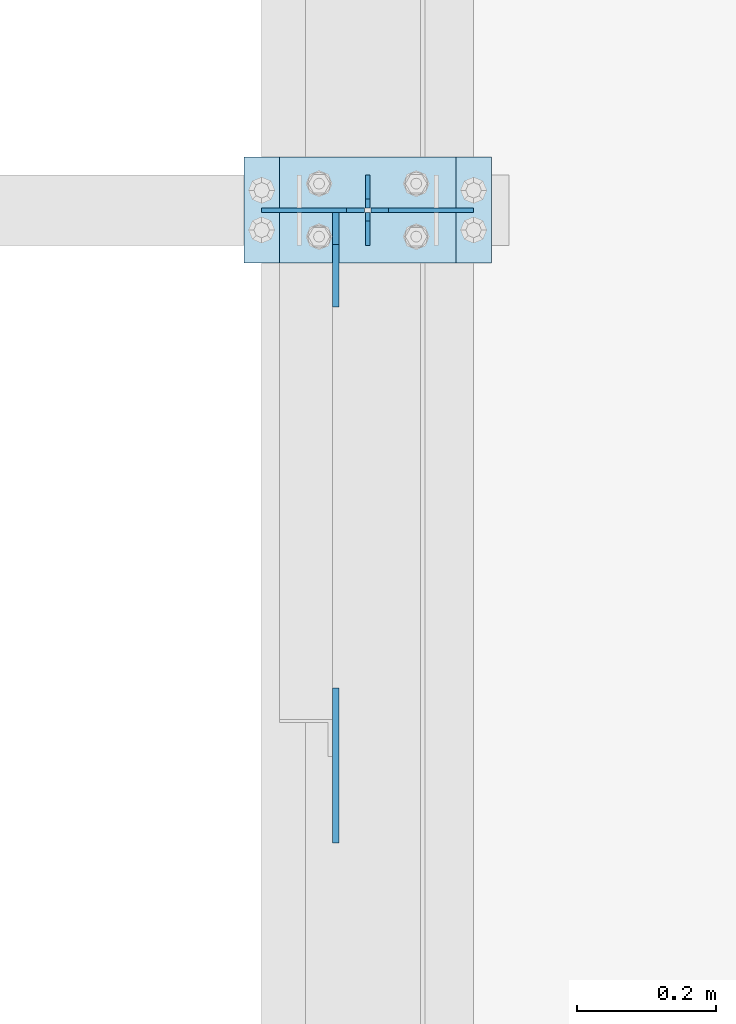
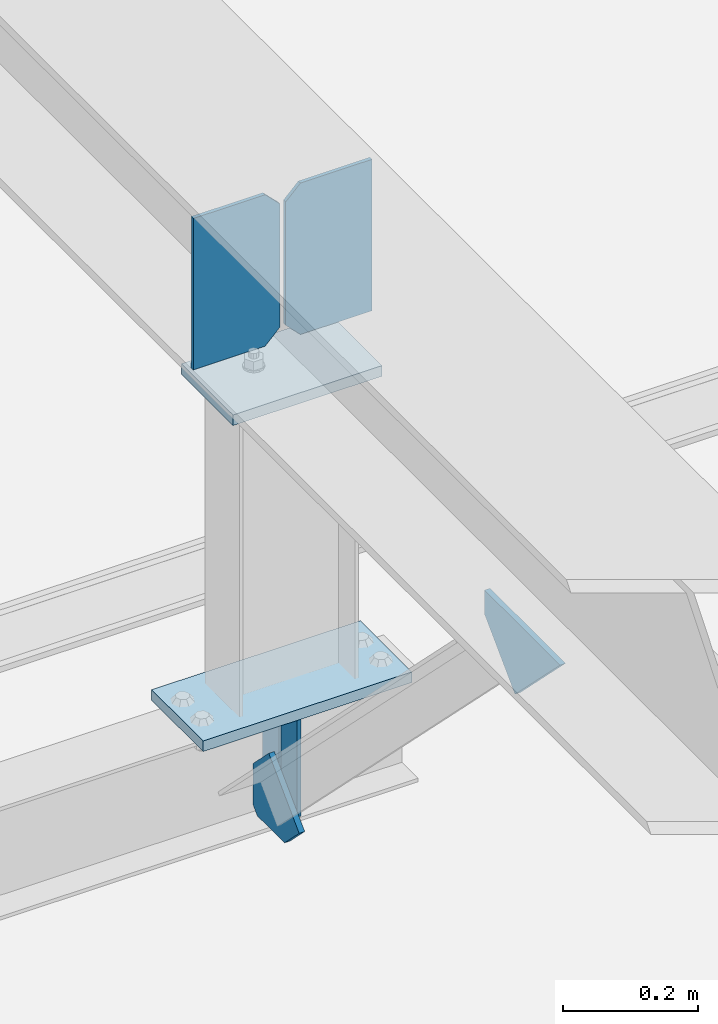
# One storey, part 3243 of 3843: 8 plates, 3 elements without a shape of their own.
"""IFC2X3 building model written with IfcOpenShell, lengths in millimetres."""

from ifc_helpers import new_model, si_unit, frame, origin_with_axes, place, context, subcontext, project, spatial, faceted_brep, material, type_object, element, aggregate, save


model = new_model("IFC2X3")

# Units and contexts
model_context = context("Model", 3, precision=1e-05, world=origin_with_axes())
body_context = subcontext(model_context, "Body", "Model", "MODEL_VIEW")
ifc_project = project(units=[si_unit("LENGTHUNIT", "METRE", prefix="MILLI"), si_unit("AREAUNIT", "SQUARE_METRE"), si_unit("VOLUMEUNIT", "CUBIC_METRE"), si_unit("MASSUNIT", "GRAM", prefix="KILO"), si_unit("TIMEUNIT", "SECOND"), si_unit("PLANEANGLEUNIT", "RADIAN"), si_unit("SOLIDANGLEUNIT", "STERADIAN"), si_unit("THERMODYNAMICTEMPERATUREUNIT", "DEGREE_CELSIUS"), si_unit("LUMINOUSINTENSITYUNIT", "LUMEN")], contexts=[model_context])

# Site, building, storey
site_placement = place(None, origin_with_axes())
site = spatial("IfcSite", under=ifc_project, at=site_placement, CompositionType="ELEMENT")
building_placement = place(site_placement, origin_with_axes())
building = spatial("IfcBuilding", under=site, at=building_placement, Name="Undefined", CompositionType="ELEMENT")
storey_placement = place(building_placement, origin_with_axes())
storey = spatial("IfcBuildingStorey", under=building, at=storey_placement, Name="Undefined", CompositionType="ELEMENT", Elevation=0.0)

# Assembly, plates
assembly_1_placement = place(storey_placement, origin_with_axes())
assembly_1 = element("IfcElementAssembly", 1, at=assembly_1_placement, inside=storey, Name="BEAM", AssemblyPlace="NOTDEFINED", PredefinedType="RIGID_FRAME")
ifc_material = material(Name="STEEL/A572-50")
plate_type_1 = type_object("IfcPlateType", PredefinedType="NOTDEFINED")
plate_1_placement = place(assembly_1_placement, frame((42062.4, 46329.6, 41495.6625), z_axis=(0.0, 0.0, -1.0), x_axis=(0.0, 1.0, 0.0)))
plate_1 = element("IfcPlate", 2, at=plate_1_placement, type_object=plate_type_1, material=ifc_material, Name="PLATE", context=body_context, shape_type="Brep", body=[
    faceted_brep([(0.0, -3.17499999999927, 0.0), (0.0, -3.17500000000291, 187.324999999997), (0.0, 3.17500000000291, 187.324999999997), (0.0, 3.17499999999927, 0.0), (34.9250001907349, -3.17500000000291, 187.324999999997), (34.9250001907349, 3.17500000000291, 187.324999999997), (47.625, -3.17500000000291, 174.625000190732), (47.625, 3.17500000000291, 174.625000190732), (47.625, -3.17499999999927, 12.6999998092651), (47.625, 3.17499999999927, 12.6999998092651), (34.9250001907349, -3.17499999999927, 0.0), (34.9250001907349, 3.17499999999927, 0.0)], [[[0, 1, 2, 3]], [[1, 4, 5, 2]], [[4, 6, 7, 5]], [[6, 8, 9, 7]], [[8, 10, 11, 9]], [[10, 0, 3, 11]], [[5, 7, 9, 11, 3, 2]], [[10, 8, 6, 4, 1, 0]]]),
])
plate_2_placement = place(assembly_1_placement, frame((42062.4, 46431.2, 41495.6625), z_axis=(0.0, 0.0, -1.0), x_axis=(0.0, -1.0, 0.0)))
plate_2 = element("IfcPlate", 3, at=plate_2_placement, type_object=plate_type_1, material=ifc_material, Name="PLATE", context=body_context, shape_type="Brep", body=[
    faceted_brep([(0.0, -3.17499999999927, 0.0), (0.0, -3.17500000000291, 187.324999999997), (0.0, 3.17500000000291, 187.324999999997), (0.0, 3.17499999999927, 0.0), (34.9250001907349, -3.17500000000291, 187.324999999997), (34.9250001907349, 3.17500000000291, 187.324999999997), (47.625, -3.17500000000291, 174.625000190732), (47.625, 3.17500000000291, 174.625000190732), (47.625, -3.17499999999927, 12.6999998092651), (47.625, 3.17499999999927, 12.6999998092651), (34.9250001907349, -3.17499999999927, 0.0), (34.9250001907349, 3.17499999999927, 0.0)], [[[0, 1, 2, 3]], [[1, 4, 5, 2]], [[4, 6, 7, 5]], [[6, 8, 9, 7]], [[8, 10, 11, 9]], [[10, 0, 3, 11]], [[5, 7, 9, 11, 3, 2]], [[10, 8, 6, 4, 1, 0]]]),
])

assembly_2_placement = place(storey_placement, origin_with_axes())
assembly_2 = element("IfcElementAssembly", 4, at=assembly_2_placement, inside=storey, Name="POST", AssemblyPlace="NOTDEFINED", PredefinedType="RIGID_FRAME")
plate_type_2 = type_object("IfcPlateType", PredefinedType="NOTDEFINED")
plate_3_placement = place(assembly_2_placement, frame((41935.3999969134, 46456.6050939797, 42083.0375013681), z_axis=(0.0, -0.999999856378788, -0.00053595000020141), x_axis=(1.0, 0.0, 0.0)))
plate_3 = element("IfcPlate", 5, at=plate_3_placement, type_object=plate_type_2, material=ifc_material, Name="PLATE", context=body_context, shape_type="Brep", body=[
    faceted_brep([(0.0, -9.52500000000146, 0.0), (0.0, -9.5249999999287, 152.40000000162), (0.0, 9.52500000002328, 152.40000000162), (0.0, 9.52500000000146, 0.0), (254.0, -9.5249999999287, 152.40000000162), (254.0, 9.52500000002328, 152.40000000162), (253.999999999998, -9.52500000000146, 0.0), (253.999999999998, 9.52500000000146, 0.0)], [[[0, 1, 2, 3]], [[1, 4, 5, 2]], [[4, 6, 7, 5]], [[6, 0, 3, 7]], [[5, 7, 3, 2]], [[6, 4, 1, 0]]]),
])
plate_4_placement = place(assembly_2_placement, frame((42240.2, 46304.2, 41513.125), z_axis=(-1.0, 0.0, 0.0), x_axis=(0.0, 1.0, 0.0)))
plate_4 = element("IfcPlate", 6, at=plate_4_placement, type_object=plate_type_2, material=ifc_material, Name="PLATE", context=body_context, shape_type="Brep", body=[
    faceted_brep([(0.0, -9.52500000000146, 0.0), (0.0, -9.52500000000146, 355.599999999999), (0.0, 9.52500000000146, 355.599999999999), (0.0, 9.52500000000146, 0.0), (152.399999999994, -9.52500000000146, 355.599999999999), (152.399999999994, 9.52500000000146, 355.599999999999), (152.400000000001, -9.52500000000146, 0.0), (152.400000000001, 9.52500000000146, 0.0)], [[[0, 1, 2, 3]], [[1, 4, 5, 2]], [[4, 6, 7, 5]], [[6, 0, 3, 7]], [[5, 7, 3, 2]], [[6, 4, 1, 0]]]),
])
aggregate(assembly_2, [plate_3, plate_4])

# Assembly, plate
assembly_3_placement = place(storey_placement, origin_with_axes())
assembly_3 = element("IfcElementAssembly", 7, at=assembly_3_placement, inside=storey, Name="BEAM", AssemblyPlace="NOTDEFINED", PredefinedType="RIGID_FRAME")
plate_type_3 = type_object("IfcPlateType", PredefinedType="NOTDEFINED")
plate_5_placement = place(assembly_3_placement, frame((42016.3625, 45470.4295260981, 42120.4744513355), z_axis=(0.0, 0.707106781186548, 0.707106781186548), x_axis=(5.70000238222118e-08, 0.707106781186546, -0.707106781186546)))
plate_5 = element("IfcPlate", 8, at=plate_5_placement, type_object=plate_type_3, material=ifc_material, Name="PLATE", context=body_context, shape_type="Brep", body=[
    faceted_brep([(0.0, -4.76249999999709, 0.0), (157.726597423803, -4.76249999999709, 157.726601438866), (157.726597423803, 4.76249999999709, 157.726601438866), (0.0, 4.76249999999709, 0.0), (188.387110059113, -4.76249999999709, 127.066089584019), (188.387110059113, 4.76249999999709, 127.066089584019), (188.387111679331, -4.76249999999709, 1.09139364212751e-10), (188.387111679331, 4.76249999999709, 1.09139364212751e-10)], [[[0, 1, 2, 3]], [[1, 4, 5, 2]], [[4, 6, 7, 5]], [[6, 0, 3, 7]], [[5, 7, 3, 2]], [[6, 4, 1, 0]]]),
])

# Plate
plate_type_4 = type_object("IfcPlateType", PredefinedType="NOTDEFINED")
plate_6_placement = place(assembly_1_placement, frame((42016.3625, 46377.2250000347, 41306.750000025), z_axis=(0.0, -1.0, 0.0), x_axis=(0.0, 0.0, 1.0)))
plate_6 = element("IfcPlate", 9, at=plate_6_placement, type_object=plate_type_4, material=ifc_material, Name="PLATE", context=body_context, shape_type="Brep", body=[
    faceted_brep([(0.0, -4.76250000000073, 12.6999998092651), (4.450703272596e-08, -4.76249999999709, 93.0710244828806), (4.450703272596e-08, 4.76249999999709, 93.0710244828806), (0.0, 4.76250000000073, 12.6999998092651), (43.3137807601452, -4.76249999999709, 136.384805065652), (43.3137807601452, 4.76249999999709, 136.384805065652), (133.209805202001, -4.76249999999709, 46.4887805392646), (133.209805202001, 4.76249999999709, 46.4887805392646), (86.7210245267561, -4.76249999999709, 0.0), (86.7210245267561, 4.76249999999709, 0.0), (12.6999998092651, -4.76250000000073, 0.0), (12.6999998092651, 4.76250000000073, 0.0)], [[[0, 1, 2, 3]], [[1, 4, 5, 2]], [[4, 6, 7, 5]], [[6, 8, 9, 7]], [[8, 10, 11, 9]], [[10, 0, 3, 11]], [[5, 7, 9, 11, 3, 2]], [[10, 8, 6, 4, 1, 0]]]),
])

aggregate(assembly_1, [plate_6, plate_1, plate_2])

plate_type_5 = type_object("IfcPlateType", PredefinedType="NOTDEFINED")
plate_7_placement = place(assembly_3_placement, frame((42214.8, 46380.2442998255, 42411.4264285813), z_axis=(0.0, 0.00053595000020141, -0.999999856378788), x_axis=(-1.0, 0.0, 0.0)))
plate_7 = element("IfcPlate", 10, at=plate_7_placement, type_object=plate_type_5, material=ifc_material, Name="PLATE", context=body_context, shape_type="Brep", body=[
    faceted_brep([(0.0, -3.17499999999927, 0.0), (0.0, -3.17500000007567, 273.049999997937), (0.0, 3.17499999993743, 273.049999997937), (0.0, 3.17499999999927, 0.0), (122.237500389827, -3.17500000007567, 273.049999997937), (122.237500389827, 3.17499999993743, 273.049999997937), (147.637500008357, -3.17500000006476, 247.650000379464), (147.637500008357, 3.17499999994106, 247.650000379464), (147.637500008357, -3.17500000001382, 25.3999996184648), (147.637500008357, 3.17499999999927, 25.3999996184648), (122.237500389827, -3.17500000000291, 0.0), (122.237500389827, 3.17500000000291, -7.27595761418343e-12)], [[[0, 1, 2, 3]], [[1, 4, 5, 2]], [[4, 6, 7, 5]], [[6, 8, 9, 7]], [[8, 10, 11, 9]], [[10, 0, 3, 11]], [[5, 7, 9, 11, 3, 2]], [[10, 8, 6, 4, 1, 0]]]),
])

plate_8_placement = place(assembly_3_placement, frame((41910.0, 46380.2442998255, 42411.4264285813), z_axis=(0.0, 0.00053595000020141, -0.999999856378788), x_axis=(1.0, 0.0, 0.0)))
plate_8 = element("IfcPlate", 11, at=plate_8_placement, type_object=plate_type_5, material=ifc_material, Name="PLATE", context=body_context, shape_type="Brep", body=[
    faceted_brep([(0.0, -3.17499999999927, 0.0), (0.0, -3.17500000007567, 273.049999997937), (0.0, 3.17499999993743, 273.049999997937), (0.0, 3.17499999999927, 0.0), (122.237500389827, -3.17500000007567, 273.049999997937), (122.237500389827, 3.17499999993743, 273.049999997937), (147.637500008357, -3.17500000006476, 247.650000379464), (147.637500008357, 3.17499999994106, 247.650000379464), (147.637500008357, -3.17500000001382, 25.3999996184648), (147.637500008357, 3.17499999999927, 25.3999996184648), (122.237500389827, -3.17500000000291, 0.0), (122.237500389827, 3.17500000000291, -7.27595761418343e-12)], [[[0, 1, 2, 3]], [[1, 4, 5, 2]], [[4, 6, 7, 5]], [[6, 8, 9, 7]], [[8, 10, 11, 9]], [[10, 0, 3, 11]], [[5, 7, 9, 11, 3, 2]], [[10, 8, 6, 4, 1, 0]]]),
])

aggregate(assembly_3, [plate_7, plate_8, plate_5])

save(model, "model.ifc")
